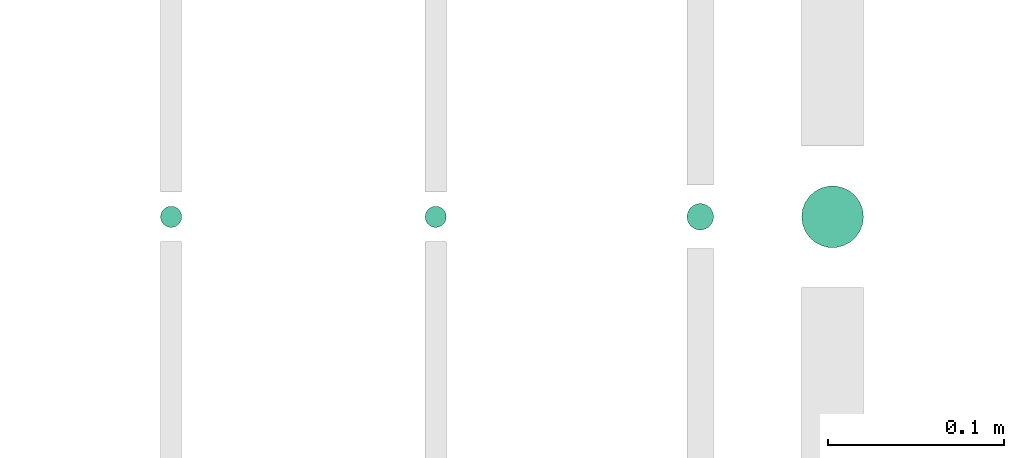
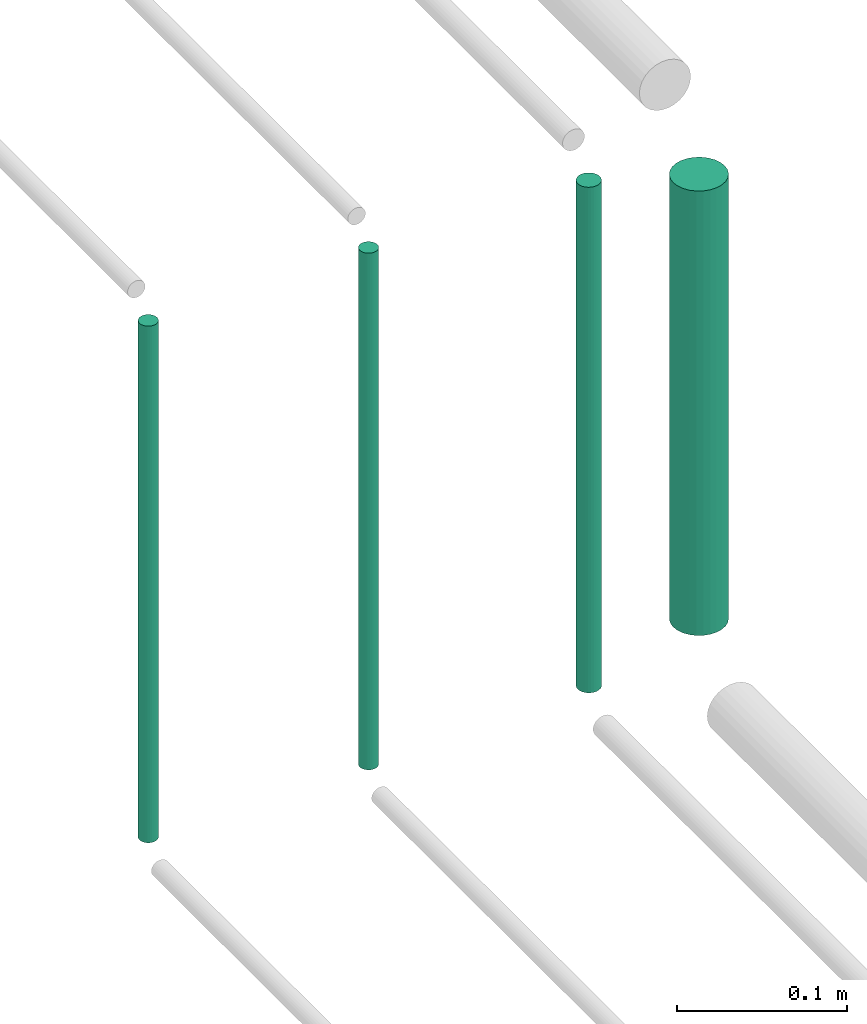
# One storey, part 242 of 331: 4 flow segments.
"""IFC2X3 building model written with IfcOpenShell, lengths in millimetres."""

from ifc_helpers import new_model, entity, si_unit, converted_unit, derived_unit, direction, frame, frame_2d, origin, origin_2d_with_axis, place, context, subcontext, project, spatial, circle, extrude, type_object, element, save


model = new_model("IFC2X3")

# Units and contexts
model_context = context("Model", 3, precision=0.01, world=origin(), true_north=direction((6.12303176911189e-17, 1.0)))
body_context = subcontext(model_context, "Body", "Model", "MODEL_VIEW")
ifc_project = project(units=[si_unit("LENGTHUNIT", "METRE", prefix="MILLI"), si_unit("AREAUNIT", "SQUARE_METRE"), si_unit("VOLUMEUNIT", "CUBIC_METRE"), converted_unit("PLANEANGLEUNIT", "DEGREE", entity("IfcRatioMeasure", 0.0174532925199433), si_unit("PLANEANGLEUNIT", "RADIAN"), dimensions=[0, 0, 0, 0, 0, 0, 0]), si_unit("MASSUNIT", "GRAM", prefix="KILO"), derived_unit("MASSDENSITYUNIT", [(si_unit("MASSUNIT", "GRAM", prefix="KILO"), 1), (si_unit("LENGTHUNIT", "METRE"), -3)]), derived_unit("MOMENTOFINERTIAUNIT", [(si_unit("LENGTHUNIT", "METRE"), 4)]), si_unit("TIMEUNIT", "SECOND"), si_unit("FREQUENCYUNIT", "HERTZ"), si_unit("THERMODYNAMICTEMPERATUREUNIT", "DEGREE_CELSIUS"), derived_unit("THERMALTRANSMITTANCEUNIT", [(si_unit("MASSUNIT", "GRAM", prefix="KILO"), 1), (si_unit("THERMODYNAMICTEMPERATUREUNIT", "KELVIN"), -1), (si_unit("TIMEUNIT", "SECOND"), -3)]), derived_unit("VOLUMETRICFLOWRATEUNIT", [(si_unit("LENGTHUNIT", "METRE"), 3), (si_unit("TIMEUNIT", "SECOND"), -1)]), derived_unit("MASSFLOWRATEUNIT", [(si_unit("MASSUNIT", "GRAM", prefix="KILO"), 1), (si_unit("TIMEUNIT", "SECOND"), -1)]), derived_unit("ROTATIONALFREQUENCYUNIT", [(si_unit("TIMEUNIT", "SECOND"), -1)]), si_unit("ELECTRICCURRENTUNIT", "AMPERE"), si_unit("ELECTRICVOLTAGEUNIT", "VOLT"), si_unit("POWERUNIT", "WATT"), si_unit("FORCEUNIT", "NEWTON", prefix="KILO"), si_unit("ILLUMINANCEUNIT", "LUX"), si_unit("LUMINOUSFLUXUNIT", "LUMEN"), si_unit("LUMINOUSINTENSITYUNIT", "CANDELA"), derived_unit("USERDEFINED", [(si_unit("MASSUNIT", "GRAM", prefix="KILO"), -1), (si_unit("LENGTHUNIT", "METRE"), -2), (si_unit("TIMEUNIT", "SECOND"), 3), (si_unit("LUMINOUSFLUXUNIT", "LUMEN"), 1)]), derived_unit("LINEARVELOCITYUNIT", [(si_unit("LENGTHUNIT", "METRE"), 1), (si_unit("TIMEUNIT", "SECOND"), -1)]), si_unit("PRESSUREUNIT", "PASCAL"), derived_unit("USERDEFINED", [(si_unit("LENGTHUNIT", "METRE"), -2), (si_unit("MASSUNIT", "GRAM", prefix="KILO"), 1), (si_unit("TIMEUNIT", "SECOND"), -2)]), derived_unit("LINEARFORCEUNIT", [(si_unit("MASSUNIT", "GRAM", prefix="KILO"), 1), (si_unit("LENGTHUNIT", "METRE"), 1), (si_unit("TIMEUNIT", "SECOND"), -2), (si_unit("LENGTHUNIT", "METRE"), -1)]), derived_unit("PLANARFORCEUNIT", [(si_unit("MASSUNIT", "GRAM", prefix="KILO"), 1), (si_unit("LENGTHUNIT", "METRE"), 1), (si_unit("TIMEUNIT", "SECOND"), -2), (si_unit("LENGTHUNIT", "METRE"), -2)])], contexts=[model_context])

# Site, building, storey
site_placement = place(None, frame((0.0, -0.00077364408347762, 0.0)))
site = spatial("IfcSite", under=ifc_project, at=site_placement, CompositionType="ELEMENT")
building_placement = place(site_placement, origin())
building = spatial("IfcBuilding", under=site, at=building_placement, CompositionType="ELEMENT")
storey_placement = place(building_placement, origin())
storey = spatial("IfcBuildingStorey", under=building, at=storey_placement, CompositionType="ELEMENT", Elevation=0.0)

# Flow segments
pipe_segment_type = type_object("IfcPipeSegmentType", PredefinedType="NOTDEFINED")
flow_segment_1_placement = place(storey_placement, frame((59746.7529497117, 16303.9730791424, 14790.0)))
element("IfcFlowSegment", 1, at=flow_segment_1_placement, inside=storey, type_object=pipe_segment_type, context=body_context, shape_type="SweptSolid", body=[
    extrude(circle(Radius=17.5, at=frame_2d((-8.66293703438714e-12, 0.0), x_axis=(1.0, 0.0))), frame((19.0952722359206, 19.0952722359163, 0.0)), (0.0, 0.0, 1.0), 320.000000000003),
])
flow_segment_2_placement = place(storey_placement, frame((59681.7529497117, 16313.9730791424, 14768.0)))
element("IfcFlowSegment", 2, at=flow_segment_2_placement, inside=storey, type_object=pipe_segment_type, context=body_context, shape_type="SweptSolid", body=[
    extrude(circle(Radius=7.5, at=origin_2d_with_axis()), frame((9.09527223591419, 9.09527223591636, 0.0)), (0.0, 0.0, 1.0), 364.000000000004),
])
for number, where in (
    (3, (59533.2529497117, 16315.4730791424, 14764.0)),
    (4, (59383.2529497117, 16315.4730791424, 14764.0)),
):
    element("IfcFlowSegment", number, at=place(storey_placement, frame(where)), inside=storey, type_object=pipe_segment_type, context=body_context, shape_type="SweptSolid", body=[
        extrude(circle(Radius=6.0, at=origin_2d_with_axis()), frame((7.59527223591454, 7.5952722359167, 0.0)), (0.0, 0.0, 1.0), 372.000000000004),
    ])

save(model, "model.ifc")
